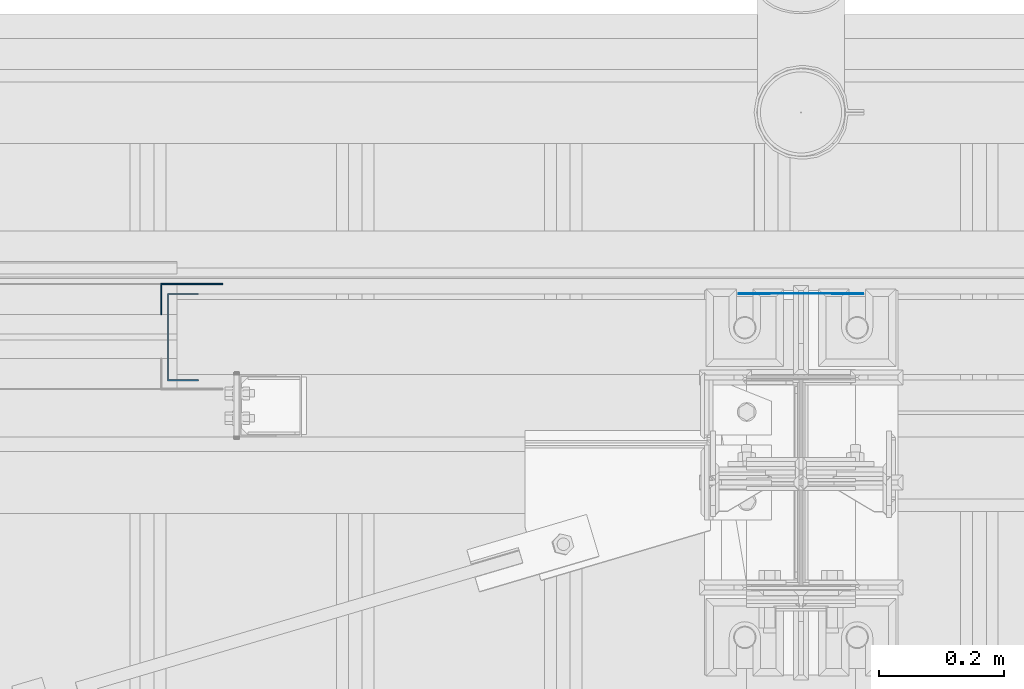
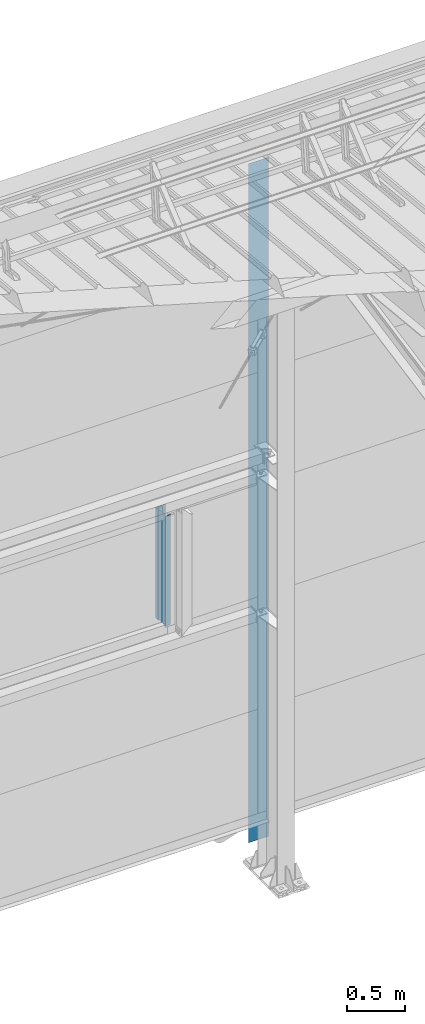
# One storey, part 16 of 709: 3 columns, 3 elements without a shape of their own.
"""IFC4 building model written with IfcOpenShell, lengths in millimetres."""

from ifc_helpers import new_model, si_unit, direction, frame, origin_with_axes, place, context, subcontext, project, spatial, line, indexed_curve, outline, extrude, material, element, aggregate, save


model = new_model("IFC4")

# Units and contexts
model_context = context("Model", 3, precision=0.2, world=origin_with_axes(), true_north=direction((0.0, 1.0)))
body_context = subcontext(model_context, "Body", "Model", "MODEL_VIEW")
ifc_project = project(units=[si_unit("LENGTHUNIT", "METRE", prefix="MILLI"), si_unit("AREAUNIT", "SQUARE_METRE"), si_unit("VOLUMEUNIT", "CUBIC_METRE"), si_unit("MASSUNIT", "GRAM", prefix="KILO"), si_unit("TIMEUNIT", "SECOND"), si_unit("PLANEANGLEUNIT", "RADIAN"), si_unit("SOLIDANGLEUNIT", "STERADIAN"), si_unit("THERMODYNAMICTEMPERATUREUNIT", "DEGREE_CELSIUS"), si_unit("LUMINOUSINTENSITYUNIT", "LUMEN")], contexts=[model_context])

# Site, building, storey
site_placement = place(None, origin_with_axes())
site = spatial("IfcSite", under=ifc_project, at=site_placement, CompositionType="ELEMENT")
building_placement = place(site_placement, origin_with_axes())
building = spatial("IfcBuilding", under=site, at=building_placement, Name="Undefined", CompositionType="ELEMENT")
storey_placement = place(building_placement, origin_with_axes())
storey = spatial("IfcBuildingStorey", under=building, at=storey_placement, Name="Undefined", CompositionType="ELEMENT", Elevation=0.0)

# Assembly, column
assembly_1_placement = place(storey_placement, frame((45010.0, 22060.0, 2700.0), z_axis=(0.0, -1.0, 0.0), x_axis=(0.0, 0.0, 1.0)))
assembly_1 = element("IfcElementAssembly", 1, at=assembly_1_placement, inside=storey)
ifc_material = material(Name="Steel_Undefined", Category="STEEL")
column_1_placement = place(assembly_1_placement, origin_with_axes())
column_1 = element("IfcColumn", 2, at=column_1_placement, material=ifc_material, context=body_context, shape_type="SolidModel", body=[
    extrude(outline(indexed_curve([(-70.0, -25.0), (-68.0, -25.0), (-68.0, 23.0), (68.0, 23.0), (68.0, -25.0), (70.0, -25.0), (70.0, 25.0), (-70.0, 25.0)], segments=[line(1, 2, 3, 4, 5, 6, 7, 8, 1)])), frame((0.0, 0.0, 0.0), z_axis=(-1.0, 0.0, 0.0), x_axis=(0.0, 0.0, 1.0)), (0.0, 0.0, -1.0), 1170.0),
])
aggregate(assembly_1, [column_1])

assembly_2_placement = place(storey_placement, frame((44975.0, 22121.0, 2700.0), z_axis=(0.0, 1.0, 0.0), x_axis=(0.0, 0.0, 1.0)))
assembly_2 = element("IfcElementAssembly", 3, at=assembly_2_placement, inside=storey)
column_2_placement = place(assembly_2_placement, origin_with_axes())
column_2 = element("IfcColumn", 4, at=column_2_placement, material=ifc_material, context=body_context, shape_type="SolidModel", body=[
    extrude(outline(indexed_curve([(-25.0, -1.0), (25.0, -1.0), (25.0, 99.0), (23.0, 99.0), (23.0, 1.0), (-25.0, 1.0)], segments=[line(1, 2, 3, 4, 5, 6, 1)])), frame((0.0, 0.0, 0.0), z_axis=(-1.0, 0.0, 0.0), x_axis=(0.0, 0.0, 1.0)), (0.0, 0.0, -1.0), 1170.0),
])
aggregate(assembly_2, [column_2])

assembly_3_placement = place(storey_placement, frame((46000.0, 22130.0, 0.0), z_axis=(0.0, -1.0, 0.0), x_axis=(0.0, 0.0, 1.0)))
assembly_3 = element("IfcElementAssembly", 5, at=assembly_3_placement, inside=storey)
column_3_placement = place(assembly_3_placement, origin_with_axes())
column_3 = element("IfcColumn", 6, at=column_3_placement, material=ifc_material, context=body_context, shape_type="SolidModel", body=[
    extrude(outline(indexed_curve([(-0.375, -100.0), (1.245, -100.0), (1.245, -50.0), (0.495, -50.0), (0.495, -99.25), (0.375, -99.25), (0.375, 99.25), (0.495, 99.25), (0.495, 50.0), (1.245, 50.0), (1.245, 100.0), (-0.375, 100.0)], segments=[line(1, 2, 3, 4, 5, 6, 7, 8, 9, 10, 11, 12, 1)])), frame((0.0, 0.0, 0.0), z_axis=(-1.0, 0.0, 0.0), x_axis=(0.0, 0.0, 1.0)), (0.0, 0.0, -1.0), 7196.92297),
])
aggregate(assembly_3, [column_3])

save(model, "model.ifc")
